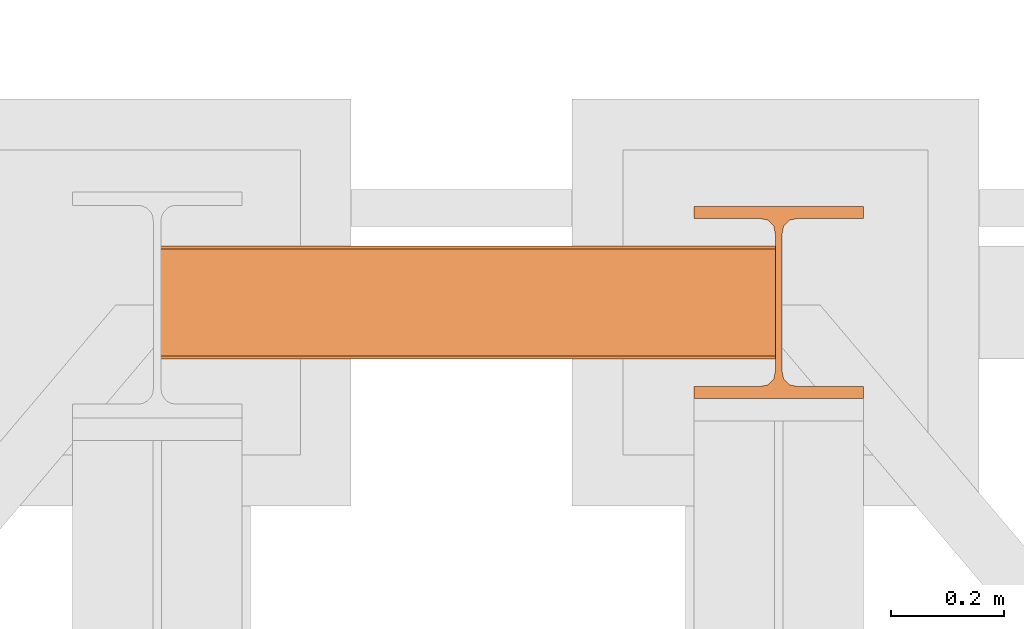
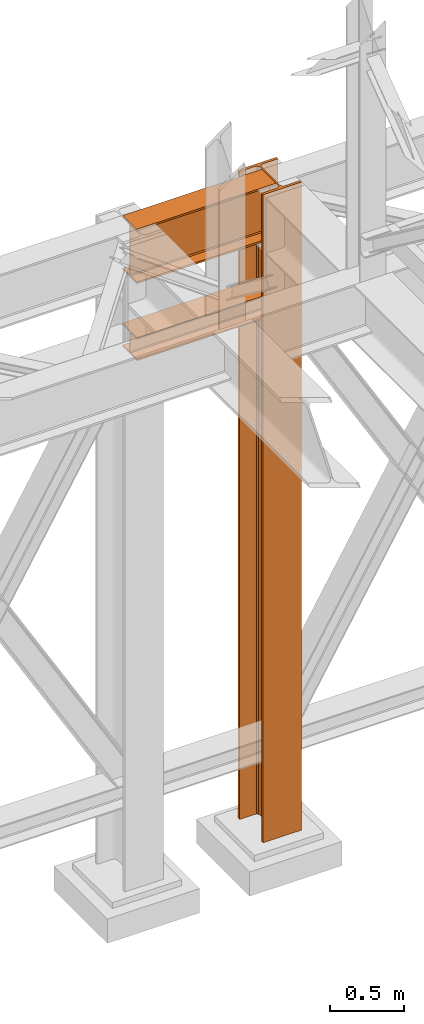
# One storey, part 142 of 208: 3 proxies.
"""IFC2X3 building model written with IfcOpenShell, lengths in millimetres."""

from ifc_helpers import new_model, entity, si_unit, converted_unit, frame, origin, origin_with_axes, place, context, subcontext, project, spatial, faceted_brep, material, element, save


model = new_model("IFC2X3")

# Units and contexts
model_context = context("Model", 3, precision=1e-05, world=origin())
plan_context = context("Plan", 3, precision=1e-05, world=origin())
body_context = subcontext(model_context, "Body", "Model", "MODEL_VIEW")
ifc_project = project(units=[si_unit("LENGTHUNIT", "METRE", prefix="MILLI"), converted_unit("PLANEANGLEUNIT", "DEGREE", entity("IfcPlaneAngleMeasure", 0.0174532925199433), si_unit("PLANEANGLEUNIT", "RADIAN"), dimensions=[0, 0, 0, 0, 0, 0, 0]), si_unit("AREAUNIT", "SQUARE_METRE"), si_unit("VOLUMEUNIT", "CUBIC_METRE")], contexts=[model_context, plan_context])

# Building, storey
building_placement = place(None, origin())
building = spatial("IfcBuilding", under=ifc_project, at=building_placement, CompositionType="COMPLEX")
storey_placement = place(building_placement, origin_with_axes())
storey = spatial("IfcBuildingStorey", under=building, at=storey_placement, Name="Geschoss", CompositionType="ELEMENT")

# Proxies
proxy_1_placement = place(storey_placement, frame((2199.254968580824, -12557.57439978601, 4834.989987483023), z_axis=(0.0, 0.0, 1.0), x_axis=(1.0, 0.0, 0.0)))
element("IfcBuildingElementProxy", 1, at=proxy_1_placement, inside=storey, context=body_context, shape_type="Brep", body=[
    faceted_brep([(1088.009999895696, 0.01000000000021828, 450.0100178813937), (1088.009999895696, 190.0100125169756, 450.0100178813937), (1088.009999895696, 190.0100125169756, 435.4100240564349), (1088.009999895696, 120.7100073045494, 435.4100091552737), (1088.009999895696, 109.841562265754, 433.2347078418734), (1088.009999895696, 101.8853126263621, 425.2784563398363), (1088.009999895696, 99.71000619068764, 414.4100113010409), (1088.009999895696, 99.71000619068764, 35.60999167919181), (1088.009999895696, 101.8853126263621, 24.74154664039634), (1088.009999895696, 109.841562265754, 16.78529513835929), (1088.009999895696, 120.7100073045494, 14.60999382495902), (1088.009999895696, 190.0100125169756, 14.60999382495902), (1088.009999895696, 190.0100125169756, 0.01000000000021828), (1088.009999895696, 0.01000000000021828, 0.01000000000021828), (1088.009999895696, 0.01000000000021828, 14.60999382495902), (1088.009999895696, 69.3100052124264, 14.60999382495902), (1088.009999895696, 80.17845025122188, 16.78529513835929), (1088.009999895696, 88.13469989061377, 24.74154664039634), (1088.009999895696, 90.3100063262882, 35.60999167919181), (1088.009999895696, 90.3100063262882, 414.4100113010409), (1088.009999895696, 88.13469989061377, 425.2784563398363), (1088.009999895696, 80.17845025122188, 433.2347078418734), (1088.009999895696, 69.3100052124264, 435.4100091552737), (1088.009999895696, 0.01000000000021828, 435.4100240564349), (1088.009999895696, 190.0100125169756, 450.0100178813937), (1088.009999895696, 0.01000000000021828, 450.0100178813937), (0.01000000000021828, 0.01000000000021828, 450.0100178813937), (0.01000000000021828, 190.0100125169756, 450.0100178813937), (1088.009999895696, 190.0100125169756, 435.4100240564349), (1088.009999895696, 190.0100125169756, 450.0100178813937), (0.01000000000021828, 190.0100125169756, 450.0100178813937), (0.01000000000021828, 190.0100125169756, 435.4100240564349), (1088.009999895696, 120.7100073045494, 435.4100091552737), (1088.009999895696, 190.0100125169756, 435.4100240564349), (0.01000000000021828, 190.0100125169756, 435.4100240564349), (0.01000000000021828, 120.7100073045494, 435.4100091552737), (1088.009999895696, 109.841562265754, 433.2347078418734), (1088.009999895696, 120.7100073045494, 435.4100091552737), (0.01000000000021828, 120.7100073045494, 435.4100091552737), (0.01000000000021828, 109.841562265754, 433.2347078418734), (1088.009999895696, 101.8853126263621, 425.2784563398363), (1088.009999895696, 109.841562265754, 433.2347078418734), (0.01000000000021828, 109.841562265754, 433.2347078418734), (0.01000000000021828, 101.8853126263621, 425.2784563398363), (1088.009999895696, 99.71000619068764, 414.4100113010409), (1088.009999895696, 101.8853126263621, 425.2784563398363), (0.01000000000021828, 101.8853126263621, 425.2784563398363), (0.01000000000021828, 99.71000619068764, 414.4100113010409), (1088.009999895696, 99.71000619068764, 35.60999167919181), (1088.009999895696, 99.71000619068764, 414.4100113010409), (0.01000000000021828, 99.71000619068764, 414.4100113010409), (0.01000000000021828, 99.71000619068764, 35.60999167919181), (1088.009999895696, 101.8853126263621, 24.74154664039634), (1088.009999895696, 99.71000619068764, 35.60999167919181), (0.01000000000021828, 99.71000619068764, 35.60999167919181), (0.01000000000021828, 101.8853126263621, 24.74154664039634), (1088.009999895696, 109.841562265754, 16.78529513835929), (1088.009999895696, 101.8853126263621, 24.74154664039634), (0.01000000000021828, 101.8853126263621, 24.74154664039634), (0.01000000000021828, 109.841562265754, 16.78529513835929), (1088.009999895696, 120.7100073045494, 14.60999382495902), (1088.009999895696, 109.841562265754, 16.78529513835929), (0.01000000000021828, 109.841562265754, 16.78529513835929), (0.01000000000021828, 120.7100073045494, 14.60999382495902), (1088.009999895696, 190.0100125169756, 14.60999382495902), (1088.009999895696, 120.7100073045494, 14.60999382495902), (0.01000000000021828, 120.7100073045494, 14.60999382495902), (0.01000000000021828, 190.0100125169756, 14.60999382495902), (1088.009999895696, 190.0100125169756, 0.01000000000021828), (1088.009999895696, 190.0100125169756, 14.60999382495902), (0.01000000000021828, 190.0100125169756, 14.60999382495902), (0.01000000000021828, 190.0100125169756, 0.01000000000021828), (1088.009999895696, 0.01000000000021828, 0.01000000000021828), (1088.009999895696, 190.0100125169756, 0.01000000000021828), (0.01000000000021828, 190.0100125169756, 0.01000000000021828), (0.01000000000021828, 0.01000000000021828, 0.01000000000021828), (1088.009999895696, 0.01000000000021828, 14.60999382495902), (1088.009999895696, 0.01000000000021828, 0.01000000000021828), (0.01000000000021828, 0.01000000000021828, 0.01000000000021828), (0.01000000000021828, 0.01000000000021828, 14.60999382495902), (1088.009999895696, 69.3100052124264, 14.60999382495902), (1088.009999895696, 0.01000000000021828, 14.60999382495902), (0.01000000000021828, 0.01000000000021828, 14.60999382495902), (0.01000000000021828, 69.3100052124264, 14.60999382495902), (1088.009999895696, 80.17845025122188, 16.78529513835929), (1088.009999895696, 69.3100052124264, 14.60999382495902), (0.01000000000021828, 69.3100052124264, 14.60999382495902), (0.01000000000021828, 80.17845025122188, 16.78529513835929), (1088.009999895696, 88.13469989061377, 24.74154664039634), (1088.009999895696, 80.17845025122188, 16.78529513835929), (0.01000000000021828, 80.17845025122188, 16.78529513835929), (0.01000000000021828, 88.13469989061377, 24.74154664039634), (1088.009999895696, 90.3100063262882, 35.60999167919181), (1088.009999895696, 88.13469989061377, 24.74154664039634), (0.01000000000021828, 88.13469989061377, 24.74154664039634), (0.01000000000021828, 90.3100063262882, 35.60999167919181), (1088.009999895696, 90.3100063262882, 414.4100113010409), (1088.009999895696, 90.3100063262882, 35.60999167919181), (0.01000000000021828, 90.3100063262882, 35.60999167919181), (0.01000000000021828, 90.3100063262882, 414.4100113010409), (1088.009999895696, 88.13469989061377, 425.2784563398363), (1088.009999895696, 90.3100063262882, 414.4100113010409), (0.01000000000021828, 90.3100063262882, 414.4100113010409), (0.01000000000021828, 88.13469989061377, 425.2784563398363), (1088.009999895696, 80.17845025122188, 433.2347078418734), (1088.009999895696, 88.13469989061377, 425.2784563398363), (0.01000000000021828, 88.13469989061377, 425.2784563398363), (0.01000000000021828, 80.17845025122188, 433.2347078418734), (1088.009999895696, 69.3100052124264, 435.4100091552737), (1088.009999895696, 80.17845025122188, 433.2347078418734), (0.01000000000021828, 80.17845025122188, 433.2347078418734), (0.01000000000021828, 69.3100052124264, 435.4100091552737), (1088.009999895696, 0.01000000000021828, 435.4100240564349), (1088.009999895696, 69.3100052124264, 435.4100091552737), (0.01000000000021828, 69.3100052124264, 435.4100091552737), (0.01000000000021828, 0.01000000000021828, 435.4100240564349), (1088.009999895696, 0.01000000000021828, 450.0100178813937), (1088.009999895696, 0.01000000000021828, 435.4100240564349), (0.01000000000021828, 0.01000000000021828, 435.4100240564349), (0.01000000000021828, 0.01000000000021828, 450.0100178813937), (0.01000000000021828, 0.01000000000021828, 450.0100178813937), (0.01000000000021828, 0.01000000000021828, 435.4100240564349), (0.01000000000021828, 69.3100052124264, 435.4100091552737), (0.01000000000021828, 80.17845025122188, 433.2347078418734), (0.01000000000021828, 88.13469989061377, 425.2784563398363), (0.01000000000021828, 90.3100063262882, 414.4100113010409), (0.01000000000021828, 90.3100063262882, 35.60999167919181), (0.01000000000021828, 88.13469989061377, 24.74154664039634), (0.01000000000021828, 80.17845025122188, 16.78529513835929), (0.01000000000021828, 69.3100052124264, 14.60999382495902), (0.01000000000021828, 0.01000000000021828, 14.60999382495902), (0.01000000000021828, 0.01000000000021828, 0.01000000000021828), (0.01000000000021828, 190.0100125169756, 0.01000000000021828), (0.01000000000021828, 190.0100125169756, 14.60999382495902), (0.01000000000021828, 120.7100073045494, 14.60999382495902), (0.01000000000021828, 109.841562265754, 16.78529513835929), (0.01000000000021828, 101.8853126263621, 24.74154664039634), (0.01000000000021828, 99.71000619068764, 35.60999167919181), (0.01000000000021828, 99.71000619068764, 414.4100113010409), (0.01000000000021828, 101.8853126263621, 425.2784563398363), (0.01000000000021828, 109.841562265754, 433.2347078418734), (0.01000000000021828, 120.7100073045494, 435.4100091552737), (0.01000000000021828, 190.0100125169756, 435.4100240564349), (0.01000000000021828, 190.0100125169756, 450.0100178813937)], [[[0, 1, 2, 3, 4, 5, 6, 7, 8, 9, 10, 11, 12, 13, 14, 15, 16, 17, 18, 19, 20, 21, 22, 23]], [[24, 25, 26, 27]], [[28, 29, 30, 31]], [[32, 33, 34, 35]], [[36, 37, 38, 39]], [[40, 41, 42, 43]], [[44, 45, 46, 47]], [[48, 49, 50, 51]], [[52, 53, 54, 55]], [[56, 57, 58, 59]], [[60, 61, 62, 63]], [[64, 65, 66, 67]], [[68, 69, 70, 71]], [[72, 73, 74, 75]], [[76, 77, 78, 79]], [[80, 81, 82, 83]], [[84, 85, 86, 87]], [[88, 89, 90, 91]], [[92, 93, 94, 95]], [[96, 97, 98, 99]], [[100, 101, 102, 103]], [[104, 105, 106, 107]], [[108, 109, 110, 111]], [[112, 113, 114, 115]], [[116, 117, 118, 119]], [[120, 121, 122, 123, 124, 125, 126, 127, 128, 129, 130, 131, 132, 133, 134, 135, 136, 137, 138, 139, 140, 141, 142, 143]]], orient=[[False], [False], [False], [False], [False], [False], [False], [False], [False], [False], [False], [False], [False], [False], [False], [False], [False], [False], [False], [False], [False], [False], [False], [False], [False], [False]]),
])
ifc_material = material(Name="35/80cm")
proxy_2_placement = place(storey_placement, frame((3143.254962568203, -12632.57439531566, -65.01000000000022), z_axis=(0.0, 0.0, 1.0), x_axis=(1.0, 0.0, 0.0)))
element("IfcBuildingElementProxy", 2, at=proxy_2_placement, inside=storey, material=ifc_material, context=body_context, shape_type="Brep", body=[
    faceted_brep([(300.0100119209292, 0.01000000000021828, 0.01000000000027512), (300.0100119209292, 21.51000631809256, 0.01000000000027512), (183.0100057816508, 21.51000631809256, 0.01000000000027512), (169.036290997863, 24.30682016372703, 0.01000000000027512), (158.8068282401564, 34.53628850936912, 0.01000000000027512), (156.0100060126188, 48.51000143051169, 0.01000000000027512), (156.0100060126188, 291.5099946951868, 0.01000000000027512), (158.8068282401564, 305.48371506691, 0.01000000000027512), (169.036290997863, 315.7131685113909, 0.01000000000027512), (183.0100057816508, 318.5099972581866, 0.01000000000027512), (300.0100119209292, 318.5099972581866, 0.01000000000027512), (300.0100119209292, 340.0100035762789, 0.01000000000027512), (0.01000000000021828, 340.0100035762789, 0.01000000000027512), (0.01000000000021828, 318.5099972581866, 0.01000000000027512), (117.0100061392786, 318.5099972581866, 0.01000000000027512), (130.9837209230664, 315.7131685113909, 0.01000000000027512), (141.213183680773, 305.48371506691, 0.01000000000027512), (144.0100059083106, 291.5099946951868, 0.01000000000027512), (144.0100059083106, 48.51000143051169, 0.01000000000027512), (141.213183680773, 34.53628850936912, 0.01000000000027512), (130.9837209230664, 24.30682016372703, 0.01000000000027512), (117.0100061392786, 21.51000631809256, 0.01000000000027512), (0.01000000000021828, 21.51000631809256, 0.01000000000027512), (0.01000000000021828, 0.01000000000021828, 0.01000000000027512), (300.0100119209292, 21.51000631809256, 5350.010005364416), (300.0100119209292, 0.01000000000021828, 5350.010005364416), (0.01000000000021828, 0.01000000000021828, 5350.010005364416), (0.01000000000021828, 21.51000631809256, 5350.010005364416), (117.0100061392786, 21.51000631809256, 5350.010005364416), (130.9837209230664, 24.30682016372703, 5350.010005364416), (141.213183680773, 34.53628850936912, 5350.010005364416), (144.0100059083106, 48.51000143051169, 5350.010005364416), (144.0100059083106, 291.5099946951868, 5350.010005364416), (141.213183680773, 305.48371506691, 5350.010005364416), (130.9837209230664, 315.7131685113909, 5350.010005364416), (117.0100061392786, 318.5099972581866, 5350.010005364416), (0.01000000000021828, 318.5099972581866, 5350.010005364416), (0.01000000000021828, 340.0100035762789, 5350.010005364416), (300.0100119209292, 340.0100035762789, 5350.010005364416), (300.0100119209292, 318.5099972581866, 5350.010005364416), (183.0100057816508, 318.5099972581866, 5350.010005364416), (169.036290997863, 315.7131685113909, 5350.010005364416), (158.8068282401564, 305.48371506691, 5350.010005364416), (156.0100060126188, 291.5099946951868, 5350.010005364416), (156.0100060126188, 48.51000143051169, 5350.010005364416), (158.8068282401564, 34.53628850936912, 5350.010005364416), (169.036290997863, 24.30682016372703, 5350.010005364416), (183.0100057816508, 21.51000631809256, 5350.010005364416), (300.0100119209292, 21.51000631809256, 0.01000000000027512), (300.0100119209292, 0.01000000000021828, 0.01000000000027512), (300.0100119209292, 0.01000000000021828, 5350.010005364416), (300.0100119209292, 21.51000631809256, 5350.010005364416), (183.0100057816508, 21.51000631809256, 0.01000000000027512), (300.0100119209292, 21.51000631809256, 0.01000000000027512), (300.0100119209292, 21.51000631809256, 5350.010005364416), (183.0100057816508, 21.51000631809256, 5350.010005364416), (169.036290997863, 24.30682016372703, 0.01000000000027512), (183.0100057816508, 21.51000631809256, 0.01000000000027512), (183.0100057816508, 21.51000631809256, 5350.010005364416), (169.036290997863, 24.30682016372703, 5350.010005364416), (158.8068282401564, 34.53628850936912, 0.01000000000027512), (169.036290997863, 24.30682016372703, 0.01000000000027512), (169.036290997863, 24.30682016372703, 5350.010005364416), (158.8068282401564, 34.53628850936912, 5350.010005364416), (156.0100060126188, 48.51000143051169, 0.01000000000027512), (158.8068282401564, 34.53628850936912, 0.01000000000027512), (158.8068282401564, 34.53628850936912, 5350.010005364416), (156.0100060126188, 48.51000143051169, 5350.010005364416), (156.0100060126188, 291.5099946951868, 0.01000000000027512), (156.0100060126188, 48.51000143051169, 0.01000000000027512), (156.0100060126188, 48.51000143051169, 5350.010005364416), (156.0100060126188, 291.5099946951868, 5350.010005364416), (158.8068282401564, 305.48371506691, 0.01000000000027512), (156.0100060126188, 291.5099946951868, 0.01000000000027512), (156.0100060126188, 291.5099946951868, 5350.010005364416), (158.8068282401564, 305.48371506691, 5350.010005364416), (169.036290997863, 315.7131685113909, 0.01000000000027512), (158.8068282401564, 305.48371506691, 0.01000000000027512), (158.8068282401564, 305.48371506691, 5350.010005364416), (169.036290997863, 315.7131685113909, 5350.010005364416), (183.0100057816508, 318.5099972581866, 0.01000000000027512), (169.036290997863, 315.7131685113909, 0.01000000000027512), (169.036290997863, 315.7131685113909, 5350.010005364416), (183.0100057816508, 318.5099972581866, 5350.010005364416), (300.0100119209292, 318.5099972581866, 0.01000000000027512), (183.0100057816508, 318.5099972581866, 0.01000000000027512), (183.0100057816508, 318.5099972581866, 5350.010005364416), (300.0100119209292, 318.5099972581866, 5350.010005364416), (300.0100119209292, 340.0100035762789, 0.01000000000027512), (300.0100119209292, 318.5099972581866, 0.01000000000027512), (300.0100119209292, 318.5099972581866, 5350.010005364416), (300.0100119209292, 340.0100035762789, 5350.010005364416), (0.01000000000021828, 340.0100035762789, 0.01000000000027512), (300.0100119209292, 340.0100035762789, 0.01000000000027512), (300.0100119209292, 340.0100035762789, 5350.010005364416), (0.01000000000021828, 340.0100035762789, 5350.010005364416), (0.01000000000021828, 318.5099972581866, 0.01000000000027512), (0.01000000000021828, 340.0100035762789, 0.01000000000027512), (0.01000000000021828, 340.0100035762789, 5350.010005364416), (0.01000000000021828, 318.5099972581866, 5350.010005364416), (117.0100061392786, 318.5099972581866, 0.01000000000027512), (0.01000000000021828, 318.5099972581866, 0.01000000000027512), (0.01000000000021828, 318.5099972581866, 5350.010005364416), (117.0100061392786, 318.5099972581866, 5350.010005364416), (130.9837209230664, 315.7131685113909, 0.01000000000027512), (117.0100061392786, 318.5099972581866, 0.01000000000027512), (117.0100061392786, 318.5099972581866, 5350.010005364416), (130.9837209230664, 315.7131685113909, 5350.010005364416), (141.213183680773, 305.48371506691, 0.01000000000027512), (130.9837209230664, 315.7131685113909, 0.01000000000027512), (130.9837209230664, 315.7131685113909, 5350.010005364416), (141.213183680773, 305.48371506691, 5350.010005364416), (144.0100059083106, 291.5099946951868, 0.01000000000027512), (141.213183680773, 305.48371506691, 0.01000000000027512), (141.213183680773, 305.48371506691, 5350.010005364416), (144.0100059083106, 291.5099946951868, 5350.010005364416), (144.0100059083106, 48.51000143051169, 0.01000000000027512), (144.0100059083106, 291.5099946951868, 0.01000000000027512), (144.0100059083106, 291.5099946951868, 5350.010005364416), (144.0100059083106, 48.51000143051169, 5350.010005364416), (141.213183680773, 34.53628850936912, 0.01000000000027512), (144.0100059083106, 48.51000143051169, 0.01000000000027512), (144.0100059083106, 48.51000143051169, 5350.010005364416), (141.213183680773, 34.53628850936912, 5350.010005364416), (130.9837209230664, 24.30682016372703, 0.01000000000027512), (141.213183680773, 34.53628850936912, 0.01000000000027512), (141.213183680773, 34.53628850936912, 5350.010005364416), (130.9837209230664, 24.30682016372703, 5350.010005364416), (117.0100061392786, 21.51000631809256, 0.01000000000027512), (130.9837209230664, 24.30682016372703, 0.01000000000027512), (130.9837209230664, 24.30682016372703, 5350.010005364416), (117.0100061392786, 21.51000631809256, 5350.010005364416), (0.01000000000021828, 21.51000631809256, 0.01000000000027512), (117.0100061392786, 21.51000631809256, 0.01000000000027512), (117.0100061392786, 21.51000631809256, 5350.010005364416), (0.01000000000021828, 21.51000631809256, 5350.010005364416), (0.01000000000021828, 0.01000000000021828, 0.01000000000027512), (0.01000000000021828, 21.51000631809256, 0.01000000000027512), (0.01000000000021828, 21.51000631809256, 5350.010005364416), (0.01000000000021828, 0.01000000000021828, 5350.010005364416), (300.0100119209292, 0.01000000000021828, 0.01000000000027512), (0.01000000000021828, 0.01000000000021828, 0.01000000000027512), (0.01000000000021828, 0.01000000000021828, 5350.010005364416), (300.0100119209292, 0.01000000000021828, 5350.010005364416)], [[[0, 1, 2, 3, 4, 5, 6, 7, 8, 9, 10, 11, 12, 13, 14, 15, 16, 17, 18, 19, 20, 21, 22, 23]], [[24, 25, 26, 27, 28, 29, 30, 31, 32, 33, 34, 35, 36, 37, 38, 39, 40, 41, 42, 43, 44, 45, 46, 47]], [[48, 49, 50, 51]], [[52, 53, 54, 55]], [[56, 57, 58, 59]], [[60, 61, 62, 63]], [[64, 65, 66, 67]], [[68, 69, 70, 71]], [[72, 73, 74, 75]], [[76, 77, 78, 79]], [[80, 81, 82, 83]], [[84, 85, 86, 87]], [[88, 89, 90, 91]], [[92, 93, 94, 95]], [[96, 97, 98, 99]], [[100, 101, 102, 103]], [[104, 105, 106, 107]], [[108, 109, 110, 111]], [[112, 113, 114, 115]], [[116, 117, 118, 119]], [[120, 121, 122, 123]], [[124, 125, 126, 127]], [[128, 129, 130, 131]], [[132, 133, 134, 135]], [[136, 137, 138, 139]], [[140, 141, 142, 143]]], orient=[[False], [False], [False], [False], [False], [False], [False], [False], [False], [False], [False], [False], [False], [False], [False], [False], [False], [False], [False], [False], [False], [False], [False], [False], [False], [False]]),
])
proxy_3_placement = place(storey_placement, frame((2199.254968580822, -12562.57439501763, 4202.989992847441), z_axis=(0.0, 0.0, 1.0), x_axis=(1.0, 0.0, 0.0)))
element("IfcBuildingElementProxy", 3, at=proxy_3_placement, inside=storey, context=body_context, shape_type="Brep", body=[
    faceted_brep([(1088.009999895692, 0.01000000000021828, 190.0100125169756), (1088.009999895692, 200.0100029802325, 190.0100125169756), (1088.009999895692, 200.0100029802325, 180.0100146031382), (1088.009999895692, 121.2600035762789, 180.0100071525576), (1088.009999895692, 111.9441915473344, 178.1454621052744), (1088.009999895692, 105.1245498640838, 171.3258190250399), (1088.009999895692, 103.2600015571716, 162.010007927418), (1088.009999895692, 103.2600015571716, 28.00999713897727), (1088.009999895692, 105.1245498640838, 18.69418604135535), (1088.009999895692, 111.9441915473344, 11.87454296112082), (1088.009999895692, 121.2600035762789, 10.00999791383765), (1088.009999895692, 200.0100029802325, 10.00999791383765), (1088.009999895692, 200.0100029802325, 0.01000000000021828), (1088.009999895692, 0.01000000000021828, 0.01000000000021828), (1088.009999895692, 0.01000000000021828, 10.00999791383765), (1088.009999895692, 78.75999940395377, 10.00999791383765), (1088.009999895692, 88.07581143289826, 11.87454296112082), (1088.009999895692, 94.89545311614893, 18.69418604135535), (1088.009999895692, 96.76000142306111, 28.00999713897727), (1088.009999895692, 96.76000142306111, 162.010007927418), (1088.009999895692, 94.89545311614893, 171.3258190250399), (1088.009999895692, 88.07581143289826, 178.1454621052744), (1088.009999895692, 78.75999940395377, 180.0100071525576), (1088.009999895692, 0.01000000000021828, 180.0100146031382), (1088.009999895692, 200.0100029802325, 190.0100125169756), (1088.009999895692, 0.01000000000021828, 190.0100125169756), (0.01000000000021828, 0.01000000000021828, 190.0100125169756), (0.01000000000021828, 200.0100029802325, 190.0100125169756), (1088.009999895692, 200.0100029802325, 180.0100146031382), (1088.009999895692, 200.0100029802325, 190.0100125169756), (0.01000000000021828, 200.0100029802325, 190.0100125169756), (0.01000000000021828, 200.0100029802325, 180.0100146031382), (1088.009999895692, 121.2600035762789, 180.0100071525576), (1088.009999895692, 200.0100029802325, 180.0100146031382), (0.01000000000021828, 200.0100029802325, 180.0100146031382), (0.01000000000021828, 121.2600035762789, 180.0100071525576), (1088.009999895692, 111.9441915473344, 178.1454621052744), (1088.009999895692, 121.2600035762789, 180.0100071525576), (0.01000000000021828, 121.2600035762789, 180.0100071525576), (0.01000000000021828, 111.9441915473344, 178.1454621052744), (1088.009999895692, 105.1245498640838, 171.3258190250399), (1088.009999895692, 111.9441915473344, 178.1454621052744), (0.01000000000021828, 111.9441915473344, 178.1454621052744), (0.01000000000021828, 105.1245498640838, 171.3258190250399), (1088.009999895692, 103.2600015571716, 162.010007927418), (1088.009999895692, 105.1245498640838, 171.3258190250399), (0.01000000000021828, 105.1245498640838, 171.3258190250399), (0.01000000000021828, 103.2600015571716, 162.010007927418), (1088.009999895692, 103.2600015571716, 28.00999713897727), (1088.009999895692, 103.2600015571716, 162.010007927418), (0.01000000000021828, 103.2600015571716, 162.010007927418), (0.01000000000021828, 103.2600015571716, 28.00999713897727), (1088.009999895692, 105.1245498640838, 18.69418604135535), (1088.009999895692, 103.2600015571716, 28.00999713897727), (0.01000000000021828, 103.2600015571716, 28.00999713897727), (0.01000000000021828, 105.1245498640838, 18.69418604135535), (1088.009999895692, 111.9441915473344, 11.87454296112082), (1088.009999895692, 105.1245498640838, 18.69418604135535), (0.01000000000021828, 105.1245498640838, 18.69418604135535), (0.01000000000021828, 111.9441915473344, 11.87454296112082), (1088.009999895692, 121.2600035762789, 10.00999791383765), (1088.009999895692, 111.9441915473344, 11.87454296112082), (0.01000000000021828, 111.9441915473344, 11.87454296112082), (0.01000000000021828, 121.2600035762789, 10.00999791383765), (1088.009999895692, 200.0100029802325, 10.00999791383765), (1088.009999895692, 121.2600035762789, 10.00999791383765), (0.01000000000021828, 121.2600035762789, 10.00999791383765), (0.01000000000021828, 200.0100029802325, 10.00999791383765), (1088.009999895692, 200.0100029802325, 0.01000000000021828), (1088.009999895692, 200.0100029802325, 10.00999791383765), (0.01000000000021828, 200.0100029802325, 10.00999791383765), (0.01000000000021828, 200.0100029802325, 0.01000000000021828), (1088.009999895692, 0.01000000000021828, 0.01000000000021828), (1088.009999895692, 200.0100029802325, 0.01000000000021828), (0.01000000000021828, 200.0100029802325, 0.01000000000021828), (0.01000000000021828, 0.01000000000021828, 0.01000000000021828), (1088.009999895692, 0.01000000000021828, 10.00999791383765), (1088.009999895692, 0.01000000000021828, 0.01000000000021828), (0.01000000000021828, 0.01000000000021828, 0.01000000000021828), (0.01000000000021828, 0.01000000000021828, 10.00999791383765), (1088.009999895692, 78.75999940395377, 10.00999791383765), (1088.009999895692, 0.01000000000021828, 10.00999791383765), (0.01000000000021828, 0.01000000000021828, 10.00999791383765), (0.01000000000021828, 78.75999940395377, 10.00999791383765), (1088.009999895692, 88.07581143289826, 11.87454296112082), (1088.009999895692, 78.75999940395377, 10.00999791383765), (0.01000000000021828, 78.75999940395377, 10.00999791383765), (0.01000000000021828, 88.07581143289826, 11.87454296112082), (1088.009999895692, 94.89545311614893, 18.69418604135535), (1088.009999895692, 88.07581143289826, 11.87454296112082), (0.01000000000021828, 88.07581143289826, 11.87454296112082), (0.01000000000021828, 94.89545311614893, 18.69418604135535), (1088.009999895692, 96.76000142306111, 28.00999713897727), (1088.009999895692, 94.89545311614893, 18.69418604135535), (0.01000000000021828, 94.89545311614893, 18.69418604135535), (0.01000000000021828, 96.76000142306111, 28.00999713897727), (1088.009999895692, 96.76000142306111, 162.010007927418), (1088.009999895692, 96.76000142306111, 28.00999713897727), (0.01000000000021828, 96.76000142306111, 28.00999713897727), (0.01000000000021828, 96.76000142306111, 162.010007927418), (1088.009999895692, 94.89545311614893, 171.3258190250399), (1088.009999895692, 96.76000142306111, 162.010007927418), (0.01000000000021828, 96.76000142306111, 162.010007927418), (0.01000000000021828, 94.89545311614893, 171.3258190250399), (1088.009999895692, 88.07581143289826, 178.1454621052744), (1088.009999895692, 94.89545311614893, 171.3258190250399), (0.01000000000021828, 94.89545311614893, 171.3258190250399), (0.01000000000021828, 88.07581143289826, 178.1454621052744), (1088.009999895692, 78.75999940395377, 180.0100071525576), (1088.009999895692, 88.07581143289826, 178.1454621052744), (0.01000000000021828, 88.07581143289826, 178.1454621052744), (0.01000000000021828, 78.75999940395377, 180.0100071525576), (1088.009999895692, 0.01000000000021828, 180.0100146031382), (1088.009999895692, 78.75999940395377, 180.0100071525576), (0.01000000000021828, 78.75999940395377, 180.0100071525576), (0.01000000000021828, 0.01000000000021828, 180.0100146031382), (1088.009999895692, 0.01000000000021828, 190.0100125169756), (1088.009999895692, 0.01000000000021828, 180.0100146031382), (0.01000000000021828, 0.01000000000021828, 180.0100146031382), (0.01000000000021828, 0.01000000000021828, 190.0100125169756), (0.01000000000021828, 0.01000000000021828, 190.0100125169756), (0.01000000000021828, 0.01000000000021828, 180.0100146031382), (0.01000000000021828, 78.75999940395377, 180.0100071525576), (0.01000000000021828, 88.07581143289826, 178.1454621052744), (0.01000000000021828, 94.89545311614893, 171.3258190250399), (0.01000000000021828, 96.76000142306111, 162.010007927418), (0.01000000000021828, 96.76000142306111, 28.00999713897727), (0.01000000000021828, 94.89545311614893, 18.69418604135535), (0.01000000000021828, 88.07581143289826, 11.87454296112082), (0.01000000000021828, 78.75999940395377, 10.00999791383765), (0.01000000000021828, 0.01000000000021828, 10.00999791383765), (0.01000000000021828, 0.01000000000021828, 0.01000000000021828), (0.01000000000021828, 200.0100029802325, 0.01000000000021828), (0.01000000000021828, 200.0100029802325, 10.00999791383765), (0.01000000000021828, 121.2600035762789, 10.00999791383765), (0.01000000000021828, 111.9441915473344, 11.87454296112082), (0.01000000000021828, 105.1245498640838, 18.69418604135535), (0.01000000000021828, 103.2600015571716, 28.00999713897727), (0.01000000000021828, 103.2600015571716, 162.010007927418), (0.01000000000021828, 105.1245498640838, 171.3258190250399), (0.01000000000021828, 111.9441915473344, 178.1454621052744), (0.01000000000021828, 121.2600035762789, 180.0100071525576), (0.01000000000021828, 200.0100029802325, 180.0100146031382), (0.01000000000021828, 200.0100029802325, 190.0100125169756)], [[[0, 1, 2, 3, 4, 5, 6, 7, 8, 9, 10, 11, 12, 13, 14, 15, 16, 17, 18, 19, 20, 21, 22, 23]], [[24, 25, 26, 27]], [[28, 29, 30, 31]], [[32, 33, 34, 35]], [[36, 37, 38, 39]], [[40, 41, 42, 43]], [[44, 45, 46, 47]], [[48, 49, 50, 51]], [[52, 53, 54, 55]], [[56, 57, 58, 59]], [[60, 61, 62, 63]], [[64, 65, 66, 67]], [[68, 69, 70, 71]], [[72, 73, 74, 75]], [[76, 77, 78, 79]], [[80, 81, 82, 83]], [[84, 85, 86, 87]], [[88, 89, 90, 91]], [[92, 93, 94, 95]], [[96, 97, 98, 99]], [[100, 101, 102, 103]], [[104, 105, 106, 107]], [[108, 109, 110, 111]], [[112, 113, 114, 115]], [[116, 117, 118, 119]], [[120, 121, 122, 123, 124, 125, 126, 127, 128, 129, 130, 131, 132, 133, 134, 135, 136, 137, 138, 139, 140, 141, 142, 143]]], orient=[[False], [False], [False], [False], [False], [False], [False], [False], [False], [False], [False], [False], [False], [False], [False], [False], [False], [False], [False], [False], [False], [False], [False], [False], [False], [False]]),
])

save(model, "model.ifc")
